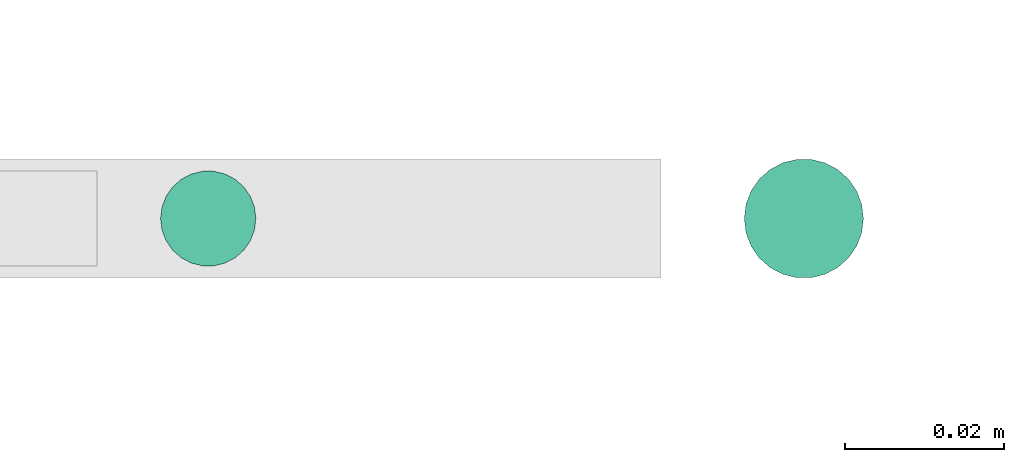
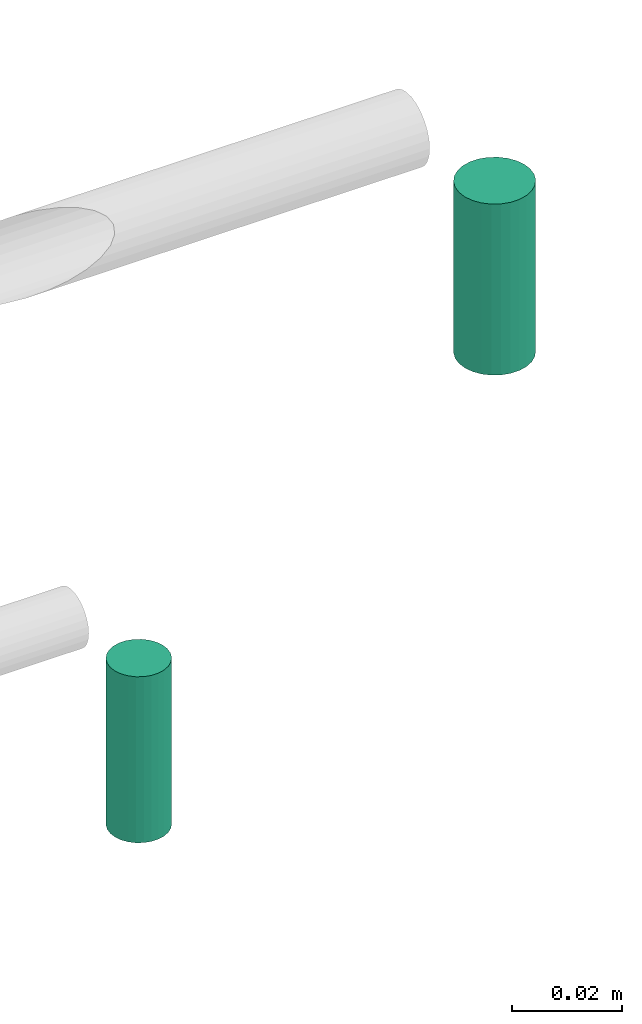
# One storey, part 67 of 89: 2 flow segments.
"""IFC2X3 building model written with IfcOpenShell, lengths in millimetres."""

from ifc_helpers import new_model, entity, si_unit, converted_unit, derived_unit, direction, frame, origin, origin_2d_with_axis, place, context, subcontext, project, spatial, circle, extrude, type_object, element, save


model = new_model("IFC2X3")

# Units and contexts
model_context = context("Model", 3, precision=0.01, world=origin(), true_north=direction((6.12303176911189e-17, 1.0)))
body_context = subcontext(model_context, "Body", "Model", "MODEL_VIEW")
ifc_project = project(units=[si_unit("LENGTHUNIT", "METRE", prefix="MILLI"), si_unit("AREAUNIT", "SQUARE_METRE"), si_unit("VOLUMEUNIT", "CUBIC_METRE"), converted_unit("PLANEANGLEUNIT", "DEGREE", entity("IfcRatioMeasure", 0.0174532925199433), si_unit("PLANEANGLEUNIT", "RADIAN"), dimensions=[0, 0, 0, 0, 0, 0, 0]), si_unit("MASSUNIT", "GRAM", prefix="KILO"), derived_unit("MASSDENSITYUNIT", [(si_unit("MASSUNIT", "GRAM", prefix="KILO"), 1), (si_unit("LENGTHUNIT", "METRE"), -3)]), derived_unit("MOMENTOFINERTIAUNIT", [(si_unit("LENGTHUNIT", "METRE"), 4)]), si_unit("TIMEUNIT", "SECOND"), si_unit("FREQUENCYUNIT", "HERTZ"), si_unit("THERMODYNAMICTEMPERATUREUNIT", "DEGREE_CELSIUS"), derived_unit("THERMALTRANSMITTANCEUNIT", [(si_unit("MASSUNIT", "GRAM", prefix="KILO"), 1), (si_unit("THERMODYNAMICTEMPERATUREUNIT", "KELVIN"), -1), (si_unit("TIMEUNIT", "SECOND"), -3)]), derived_unit("VOLUMETRICFLOWRATEUNIT", [(si_unit("LENGTHUNIT", "METRE"), 3), (si_unit("TIMEUNIT", "SECOND"), -1)]), derived_unit("MASSFLOWRATEUNIT", [(si_unit("MASSUNIT", "GRAM", prefix="KILO"), 1), (si_unit("TIMEUNIT", "SECOND"), -1)]), derived_unit("ROTATIONALFREQUENCYUNIT", [(si_unit("TIMEUNIT", "SECOND"), -1)]), si_unit("ELECTRICCURRENTUNIT", "AMPERE"), si_unit("ELECTRICVOLTAGEUNIT", "VOLT"), si_unit("POWERUNIT", "WATT"), si_unit("FORCEUNIT", "NEWTON", prefix="KILO"), si_unit("ILLUMINANCEUNIT", "LUX"), si_unit("LUMINOUSFLUXUNIT", "LUMEN"), si_unit("LUMINOUSINTENSITYUNIT", "CANDELA"), derived_unit("USERDEFINED", [(si_unit("MASSUNIT", "GRAM", prefix="KILO"), -1), (si_unit("LENGTHUNIT", "METRE"), -2), (si_unit("TIMEUNIT", "SECOND"), 3), (si_unit("LUMINOUSFLUXUNIT", "LUMEN"), 1)]), derived_unit("LINEARVELOCITYUNIT", [(si_unit("LENGTHUNIT", "METRE"), 1), (si_unit("TIMEUNIT", "SECOND"), -1)]), si_unit("PRESSUREUNIT", "PASCAL"), derived_unit("USERDEFINED", [(si_unit("LENGTHUNIT", "METRE"), -2), (si_unit("MASSUNIT", "GRAM", prefix="KILO"), 1), (si_unit("TIMEUNIT", "SECOND"), -2)]), derived_unit("LINEARFORCEUNIT", [(si_unit("MASSUNIT", "GRAM", prefix="KILO"), 1), (si_unit("LENGTHUNIT", "METRE"), 1), (si_unit("TIMEUNIT", "SECOND"), -2), (si_unit("LENGTHUNIT", "METRE"), -1)]), derived_unit("PLANARFORCEUNIT", [(si_unit("MASSUNIT", "GRAM", prefix="KILO"), 1), (si_unit("LENGTHUNIT", "METRE"), 1), (si_unit("TIMEUNIT", "SECOND"), -2), (si_unit("LENGTHUNIT", "METRE"), -2)])], contexts=[model_context])

# Site, building, storey
site_placement = place(None, frame((0.0, -0.00077364408347762, 0.0)))
site = spatial("IfcSite", under=ifc_project, at=site_placement, CompositionType="ELEMENT")
building_placement = place(site_placement, origin())
building = spatial("IfcBuilding", under=site, at=building_placement, CompositionType="ELEMENT")
storey_placement = place(building_placement, frame((0.0, 0.0, 24000.0)))
storey = spatial("IfcBuildingStorey", under=building, at=storey_placement, CompositionType="ELEMENT", Elevation=24000.0)

# Flow segments
pipe_segment_type = type_object("IfcPipeSegmentType", PredefinedType="NOTDEFINED")
flow_segment_1_placement = place(storey_placement, frame((25705.1436346568, 9267.40472776415, -5386.0)))
element("IfcFlowSegment", 1, at=flow_segment_1_placement, inside=storey, type_object=pipe_segment_type, context=body_context, shape_type="SweptSolid", body=[
    extrude(circle(Radius=6.0, at=origin_2d_with_axis()), frame((7.59527223591454, 7.59527223591562, 0.0)), (0.0, 0.0, 1.0), 37.0000000000479),
])
flow_segment_2_placement = place(storey_placement, frame((25778.6436346568, 9265.90472776419, -5307.0)))
element("IfcFlowSegment", 2, at=flow_segment_2_placement, inside=storey, type_object=pipe_segment_type, context=body_context, shape_type="SweptSolid", body=[
    extrude(circle(Radius=7.5, at=origin_2d_with_axis()), frame((9.09527223591419, 9.09527223591636, 0.0), z_axis=(0.0, 0.0, 1.0), x_axis=(-1.0, 0.0, 0.0)), (0.0, 0.0, 1.0), 38.1232479879341),
])

save(model, "model.ifc")
